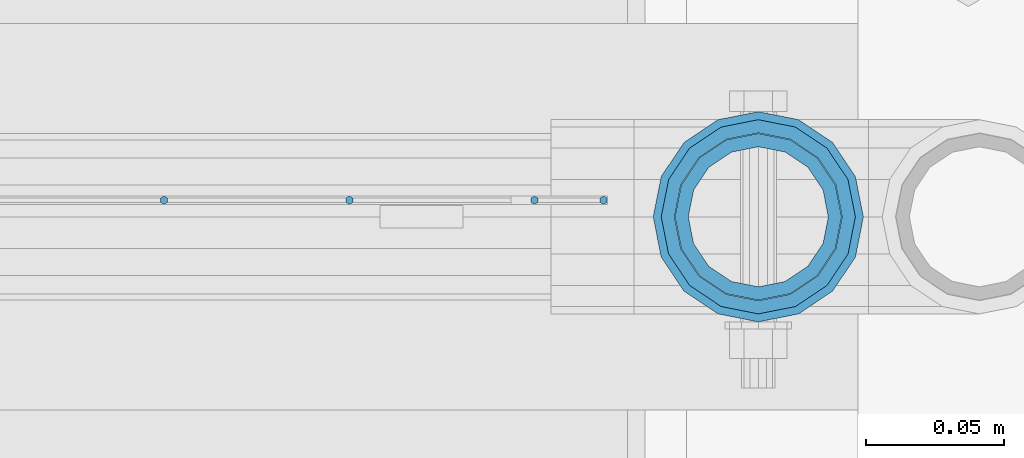
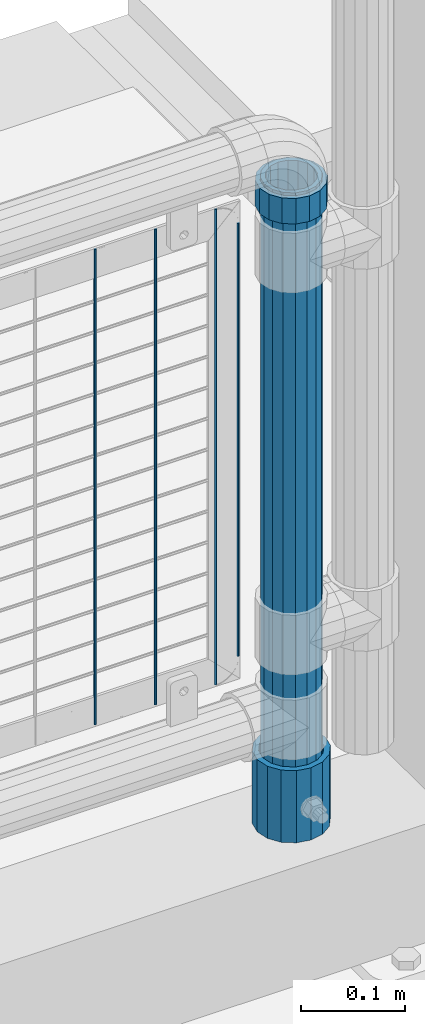
# One storey, part 99 of 257: 7 columns.
"""IFC2X3 building model written with IfcOpenShell, lengths in millimetres."""

from ifc_helpers import new_model, si_unit, frame, origin_with_axes, place, context, subcontext, project, spatial, faceted_brep, material, type_object, element, save


model = new_model("IFC2X3")

# Units and contexts
model_context = context("Model", 3, precision=1e-05, world=origin_with_axes())
body_context = subcontext(model_context, "Body", "Model", "MODEL_VIEW")
ifc_project = project(units=[si_unit("LENGTHUNIT", "METRE", prefix="MILLI"), si_unit("AREAUNIT", "SQUARE_METRE"), si_unit("VOLUMEUNIT", "CUBIC_METRE"), si_unit("MASSUNIT", "GRAM", prefix="KILO"), si_unit("TIMEUNIT", "SECOND"), si_unit("PLANEANGLEUNIT", "RADIAN"), si_unit("SOLIDANGLEUNIT", "STERADIAN"), si_unit("THERMODYNAMICTEMPERATUREUNIT", "DEGREE_CELSIUS"), si_unit("LUMINOUSINTENSITYUNIT", "LUMEN")], contexts=[model_context])

# Site, building, storey
site_placement = place(None, origin_with_axes())
site = spatial("IfcSite", under=ifc_project, at=site_placement, CompositionType="ELEMENT")
building_placement = place(site_placement, origin_with_axes())
building = spatial("IfcBuilding", under=site, at=building_placement, Name="Standard", CompositionType="ELEMENT")
storey_placement = place(building_placement, origin_with_axes())
storey = spatial("IfcBuildingStorey", under=building, at=storey_placement, Name="Undefined", CompositionType="ELEMENT", Elevation=0.0)

# Columns
ifc_material_1 = material()
column_type_1 = type_object("IfcColumnType", PredefinedType="NOTDEFINED")
column_1_placement = place(storey_placement, frame((58671.0, 10664.5, 168.019999999998), z_axis=(0.0, 1.0, 0.0), x_axis=(0.0, 0.0, 1.0)))
element("IfcColumn", 1, at=column_1_placement, inside=storey, type_object=column_type_1, material=ifc_material_1, context=body_context, shape_type="Brep", body=[
    faceted_brep([(0.0, -31.75, 0.0), (0.0, -29.3331751572332, 12.1501989775916), (85.0, -29.3331751572332, 12.1501989775916), (85.0, -31.75, 0.0), (0.0, -22.4506403026753, 22.4506403026735), (85.0, -22.4506403026753, 22.4506403026735), (0.0, -12.1501989775934, 29.3331751572332), (85.0, -12.1501989775934, 29.3331751572332), (0.0, 0.0, 31.75), (85.0, 0.0, 31.75), (0.0, 12.1501989775934, 29.3331751572332), (85.0, 12.1501989775934, 29.3331751572332), (0.0, 22.4506403026753, 22.4506403026735), (85.0, 22.4506403026753, 22.4506403026735), (0.0, 29.3331751572332, 12.1501989775916), (85.0, 29.3331751572332, 12.1501989775916), (0.0, 31.75, 0.0), (85.0, 31.75, 0.0), (0.0, 29.3331751572332, -12.1501989775916), (85.0, 29.3331751572332, -12.1501989775916), (0.0, 22.4506403026753, -22.4506403026735), (85.0, 22.4506403026753, -22.4506403026735), (0.0, 12.1501989775934, -29.3331751572332), (85.0, 12.1501989775934, -29.3331751572332), (0.0, 0.0, -31.75), (85.0, 0.0, -31.75), (0.0, -12.1501989775934, -29.3331751572332), (85.0, -12.1501989775934, -29.3331751572332), (0.0, -22.4506403026753, -22.4506403026735), (85.0, -22.4506403026753, -22.4506403026735), (0.0, -29.3331751572332, -12.1501989775916), (85.0, -29.3331751572332, -12.1501989775916), (0.0, -38.0500000000029, 0.0), (0.0, -35.1536162120537, -14.561104601491), (85.0, -35.1536162120537, -14.561104601491), (85.0, -38.0500000000029, 0.0), (0.0, -26.9054130241493, -26.9054130241475), (85.0, -26.9054130241493, -26.9054130241475), (0.0, -14.5611046014892, -35.1536162120537), (85.0, -14.5611046014892, -35.1536162120537), (0.0, 0.0, -38.0499999999993), (85.0, 0.0, -38.0499999999993), (0.0, 14.5611046014892, -35.1536162120537), (85.0, 14.5611046014892, -35.1536162120537), (0.0, 26.9054130241493, -26.9054130241475), (85.0, 26.9054130241493, -26.9054130241475), (0.0, 35.1536162120537, -14.561104601491), (85.0, 35.1536162120537, -14.561104601491), (0.0, 38.0500000000029, 0.0), (85.0, 38.0500000000029, 0.0), (0.0, 35.1536162120537, 14.561104601491), (85.0, 35.1536162120537, 14.561104601491), (0.0, 26.9054130241493, 26.9054130241475), (85.0, 26.9054130241493, 26.9054130241475), (0.0, 14.5611046014892, 35.1536162120537), (85.0, 14.5611046014892, 35.1536162120537), (0.0, 0.0, 38.0499999999993), (85.0, 0.0, 38.0499999999993), (0.0, -14.5611046014892, 35.1536162120537), (85.0, -14.5611046014892, 35.1536162120537), (0.0, -26.9054130241493, 26.9054130241475), (85.0, -26.9054130241493, 26.9054130241475), (0.0, -35.1536162120537, 14.561104601491), (85.0, -35.1536162120537, 14.561104601491)], [[[0, 1, 2, 3]], [[1, 4, 5, 2]], [[4, 6, 7, 5]], [[6, 8, 9, 7]], [[8, 10, 11, 9]], [[10, 12, 13, 11]], [[12, 14, 15, 13]], [[14, 16, 17, 15]], [[16, 18, 19, 17]], [[18, 20, 21, 19]], [[20, 22, 23, 21]], [[22, 24, 25, 23]], [[24, 26, 27, 25]], [[26, 28, 29, 27]], [[28, 30, 31, 29]], [[30, 0, 3, 31]], [[32, 33, 34, 35]], [[33, 36, 37, 34]], [[36, 38, 39, 37]], [[38, 40, 41, 39]], [[40, 42, 43, 41]], [[42, 44, 45, 43]], [[44, 46, 47, 45]], [[46, 48, 49, 47]], [[48, 50, 51, 49]], [[50, 52, 53, 51]], [[52, 54, 55, 53]], [[54, 56, 57, 55]], [[56, 58, 59, 57]], [[58, 60, 61, 59]], [[60, 62, 63, 61]], [[62, 32, 35, 63]], [[37, 39, 41, 43, 45, 47, 49, 51, 53, 55, 57, 59, 61, 63, 35, 34], [5, 7, 9, 11, 13, 15, 17, 19, 21, 23, 25, 27, 29, 31, 3, 2]], [[62, 60, 58, 56, 54, 52, 50, 48, 46, 44, 42, 40, 38, 36, 33, 32], [30, 28, 26, 24, 22, 20, 18, 16, 14, 12, 10, 8, 6, 4, 1, 0]]]),
])
ifc_material_2 = material(Name="Misc_Undefined")
column_type_2 = type_object("IfcColumnType", PredefinedType="NOTDEFINED")
column_2_placement = place(storey_placement, frame((58671.0, 10664.5, 894.85), z_axis=(1.0, 0.0, 0.0), x_axis=(0.0, 0.0, 1.0)))
element("IfcColumn", 2, at=column_2_placement, inside=storey, type_object=column_type_2, material=ifc_material_2, context=body_context, shape_type="Brep", body=[
    faceted_brep([(0.0, -30.3500000000004, 0.0), (0.0, -28.0397438117179, 11.6144421722784), (30.0, -28.0397438117179, 11.6144421722805), (30.0, -30.3500000000004, 0.0), (0.0, -21.4606908090118, 21.4606908090136), (30.0, -21.4606908090118, 21.4606908090117), (0.0, -11.6144421722802, 28.0397438117143), (30.0, -11.6144421722802, 28.0397438117175), (0.0, 0.0, 30.3499999999985), (30.0, 0.0, 30.35), (0.0, 11.6144421722802, 28.0397438117143), (30.0, 11.6144421722802, 28.0397438117175), (0.0, 21.4606908090118, 21.4606908090136), (30.0, 21.4606908090118, 21.4606908090117), (0.0, 28.0397438117179, 11.6144421722784), (30.0, 28.0397438117179, 11.6144421722805), (0.0, 30.3500000000004, 0.0), (30.0, 30.3500000000004, 0.0), (0.0, 28.0397438117179, -11.6144421722784), (30.0, 28.0397438117179, -11.6144421722805), (0.0, 21.4606908090118, -21.4606908090136), (30.0, 21.4606908090118, -21.4606908090117), (0.0, 11.6144421722802, -28.0397438117143), (30.0, 11.6144421722802, -28.0397438117175), (0.0, 0.0, -30.3499999999985), (30.0, 0.0, -30.35), (0.0, -11.6144421722802, -28.0397438117143), (30.0, -11.6144421722802, -28.0397438117175), (0.0, -21.4606908090118, -21.4606908090136), (30.0, -21.4606908090118, -21.4606908090117), (0.0, -28.0397438117179, -11.6144421722784), (30.0, -28.0397438117179, -11.6144421722805), (0.0, -35.1499999999996, 0.0), (0.0, -32.4743655677721, -13.4513226476338), (30.0, -32.4743655677721, -13.4513226476329), (30.0, -35.1499999999996, 0.0), (0.0, -24.8548033587067, -24.8548033587067), (30.0, -24.8548033587067, -24.8548033587072), (0.0, -13.4513226476338, -32.4743655677739), (30.0, -13.4513226476338, -32.4743655677717), (0.0, 0.0, -35.1499999999996), (30.0, 0.0, -35.15), (0.0, 13.4513226476338, -32.4743655677739), (30.0, 13.4513226476338, -32.4743655677717), (0.0, 24.8548033587067, -24.8548033587067), (30.0, 24.8548033587067, -24.8548033587072), (0.0, 32.4743655677721, -13.4513226476338), (30.0, 32.4743655677721, -13.4513226476329), (0.0, 35.1499999999996, 0.0), (30.0, 35.1499999999996, 0.0), (0.0, 32.4743655677721, 13.4513226476338), (30.0, 32.4743655677721, 13.4513226476329), (0.0, 24.8548033587067, 24.8548033587067), (30.0, 24.8548033587067, 24.8548033587072), (0.0, 13.4513226476338, 32.4743655677739), (30.0, 13.4513226476338, 32.4743655677717), (0.0, 0.0, 35.1499999999996), (30.0, 0.0, 35.15), (0.0, -13.4513226476338, 32.4743655677739), (30.0, -13.4513226476338, 32.4743655677717), (0.0, -24.8548033587067, 24.8548033587067), (30.0, -24.8548033587067, 24.8548033587072), (0.0, -32.4743655677721, 13.4513226476338), (30.0, -32.4743655677721, 13.4513226476329)], [[[0, 1, 2, 3]], [[1, 4, 5, 2]], [[4, 6, 7, 5]], [[6, 8, 9, 7]], [[8, 10, 11, 9]], [[10, 12, 13, 11]], [[12, 14, 15, 13]], [[14, 16, 17, 15]], [[16, 18, 19, 17]], [[18, 20, 21, 19]], [[20, 22, 23, 21]], [[22, 24, 25, 23]], [[24, 26, 27, 25]], [[26, 28, 29, 27]], [[28, 30, 31, 29]], [[30, 0, 3, 31]], [[32, 33, 34, 35]], [[33, 36, 37, 34]], [[36, 38, 39, 37]], [[38, 40, 41, 39]], [[40, 42, 43, 41]], [[42, 44, 45, 43]], [[44, 46, 47, 45]], [[46, 48, 49, 47]], [[48, 50, 51, 49]], [[50, 52, 53, 51]], [[52, 54, 55, 53]], [[54, 56, 57, 55]], [[56, 58, 59, 57]], [[58, 60, 61, 59]], [[60, 62, 63, 61]], [[62, 32, 35, 63]], [[37, 39, 41, 43, 45, 47, 49, 51, 53, 55, 57, 59, 61, 63, 35, 34], [5, 7, 9, 11, 13, 15, 17, 19, 21, 23, 25, 27, 29, 31, 3, 2]], [[62, 60, 58, 56, 54, 52, 50, 48, 46, 44, 42, 40, 38, 36, 33, 32], [30, 28, 26, 24, 22, 20, 18, 16, 14, 12, 10, 8, 6, 4, 1, 0]]]),
])
column_type_3 = type_object("IfcColumnType", PredefinedType="NOTDEFINED")
column_3_placement = place(storey_placement, frame((58671.0, 10664.5, 168.019999999998), z_axis=(-1.0, 0.0, 0.0), x_axis=(0.0, 0.0, 1.0)))
element("IfcColumn", 3, at=column_3_placement, inside=storey, type_object=column_type_3, material=ifc_material_1, context=body_context, shape_type="Brep", body=[
    faceted_brep([(0.0, -25.3500000000004, 0.0), (0.0, -23.4203461491616, 9.70102501045767), (760.0, -23.4203461491616, 9.70102501045767), (760.0, -25.3500000000004, 0.0), (0.0, -17.9251569030785, 17.9251569030821), (760.0, -17.9251569030785, 17.9251569030821), (0.0, -9.70102501045585, 23.4203461491634), (760.0, -9.70102501045585, 23.4203461491634), (0.0, 0.0, 25.3499999999985), (760.0, 0.0, 25.3499999999985), (0.0, 9.70102501045585, 23.4203461491634), (760.0, 9.70102501045585, 23.4203461491634), (0.0, 17.9251569030785, 17.9251569030821), (760.0, 17.9251569030785, 17.9251569030821), (0.0, 23.4203461491616, 9.70102501045767), (760.0, 23.4203461491616, 9.70102501045767), (0.0, 25.3500000000004, 0.0), (760.0, 25.3500000000004, 0.0), (0.0, 23.4203461491616, -9.70102501045767), (760.0, 23.4203461491616, -9.70102501045767), (0.0, 17.9251569030785, -17.9251569030821), (760.0, 17.9251569030785, -17.9251569030821), (0.0, 9.70102501045585, -23.4203461491634), (760.0, 9.70102501045585, -23.4203461491634), (0.0, 0.0, -25.3499999999985), (760.0, 0.0, -25.3499999999985), (0.0, -9.70102501045585, -23.4203461491634), (760.0, -9.70102501045585, -23.4203461491634), (0.0, -17.9251569030785, -17.9251569030821), (760.0, -17.9251569030785, -17.9251569030821), (0.0, -23.4203461491616, -9.70102501045767), (760.0, -23.4203461491616, -9.70102501045767), (0.0, -30.1499999999996, 0.0), (0.0, -27.8549679052157, -11.5379054858058), (760.0, -27.8549679052157, -11.5379054858058), (760.0, -30.1499999999996, 0.0), (0.0, -21.3192694527752, -21.3192694527752), (760.0, -21.3192694527752, -21.3192694527752), (0.0, -11.5379054858076, -27.8549679052157), (760.0, -11.5379054858076, -27.8549679052157), (0.0, 0.0, -30.1500000000015), (760.0, 0.0, -30.1500000000015), (0.0, 11.5379054858076, -27.8549679052157), (760.0, 11.5379054858076, -27.8549679052157), (0.0, 21.3192694527752, -21.3192694527752), (760.0, 21.3192694527752, -21.3192694527752), (0.0, 27.8549679052157, -11.5379054858058), (760.0, 27.8549679052157, -11.5379054858058), (0.0, 30.1499999999996, 0.0), (760.0, 30.1499999999996, 0.0), (0.0, 27.8549679052157, 11.5379054858058), (760.0, 27.8549679052157, 11.5379054858058), (0.0, 21.3192694527752, 21.3192694527752), (760.0, 21.3192694527752, 21.3192694527752), (0.0, 11.5379054858076, 27.8549679052157), (760.0, 11.5379054858076, 27.8549679052157), (0.0, 0.0, 30.1500000000015), (760.0, 0.0, 30.1500000000015), (0.0, -11.5379054858076, 27.8549679052157), (760.0, -11.5379054858076, 27.8549679052157), (0.0, -21.3192694527752, 21.3192694527752), (760.0, -21.3192694527752, 21.3192694527752), (0.0, -27.8549679052157, 11.5379054858058), (760.0, -27.8549679052157, 11.5379054858058)], [[[0, 1, 2, 3]], [[1, 4, 5, 2]], [[4, 6, 7, 5]], [[6, 8, 9, 7]], [[8, 10, 11, 9]], [[10, 12, 13, 11]], [[12, 14, 15, 13]], [[14, 16, 17, 15]], [[16, 18, 19, 17]], [[18, 20, 21, 19]], [[20, 22, 23, 21]], [[22, 24, 25, 23]], [[24, 26, 27, 25]], [[26, 28, 29, 27]], [[28, 30, 31, 29]], [[30, 0, 3, 31]], [[32, 33, 34, 35]], [[33, 36, 37, 34]], [[36, 38, 39, 37]], [[38, 40, 41, 39]], [[40, 42, 43, 41]], [[42, 44, 45, 43]], [[44, 46, 47, 45]], [[46, 48, 49, 47]], [[48, 50, 51, 49]], [[50, 52, 53, 51]], [[52, 54, 55, 53]], [[54, 56, 57, 55]], [[56, 58, 59, 57]], [[58, 60, 61, 59]], [[60, 62, 63, 61]], [[62, 32, 35, 63]], [[37, 39, 41, 43, 45, 47, 49, 51, 53, 55, 57, 59, 61, 63, 35, 34], [5, 7, 9, 11, 13, 15, 17, 19, 21, 23, 25, 27, 29, 31, 3, 2]], [[62, 60, 58, 56, 54, 52, 50, 48, 46, 44, 42, 40, 38, 36, 33, 32], [30, 28, 26, 24, 22, 20, 18, 16, 14, 12, 10, 8, 6, 4, 1, 0]]]),
])
column_type_4 = type_object("IfcColumnType", Name="D3", PredefinedType="NOTDEFINED")
for number, where, z_axis, x_axis in (
    (4, (58590.0020000001, 10670.4997841009, 353.02), (-1.0, 0.0, 0.0), (0.0, 0.0, 1.0)),
    (5, (58522.9740000001, 10670.4997983097, 353.02), (-1.0, 0.0, 0.0), (0.0, 0.0, 1.0)),
    (6, (58455.9460000001, 10670.4998125185, 353.02), (-1.0, 0.0, 0.0), (0.0, 0.0, 1.0)),
):
    element("IfcColumn", number, at=place(storey_placement, frame(where, z_axis=z_axis, x_axis=x_axis)), inside=storey, type_object=column_type_4, material=ifc_material_2, ObjectType="D3", context=body_context, shape_type="Brep", body=[
        faceted_brep([(0.0, -1.5, -5.6843418860808e-14), (0.0, -0.750000000001819, -1.29903810567669), (560.0, -0.75, -1.29903810567339), (560.0, -1.5, 0.0), (7.27595761418343e-12, 0.749999999998181, -1.29903810567669), (560.0, 0.75, -1.29903810567339), (0.0, 1.5, -5.6843418860808e-14), (560.0, 1.5, 0.0), (7.27595761418343e-12, 0.749999999998181, 1.29903810567669), (560.0, 0.75, 1.29903810567339), (0.0, -0.750000000001819, 1.29903810567669), (560.0, -0.75, 1.29903810567339)], [[[0, 1, 2, 3]], [[1, 4, 5, 2]], [[4, 6, 7, 5]], [[6, 8, 9, 7]], [[8, 10, 11, 9]], [[10, 0, 3, 11]], [[5, 7, 9, 11, 3, 2]], [[10, 8, 6, 4, 1, 0]]]),
    ])
column_4_placement = place(storey_placement, frame((58615.0000000001, 10670.4997788013, 378.02), z_axis=(-1.0, 0.0, 0.0), x_axis=(0.0, 0.0, 1.0)))
element("IfcColumn", 7, at=column_4_placement, inside=storey, type_object=column_type_4, material=ifc_material_2, ObjectType="D3", context=body_context, shape_type="Brep", body=[
    faceted_brep([(0.0, -1.5, -5.6843418860808e-14), (0.0, -0.750000000001819, -1.29903810567669), (510.0, -0.75, -1.29903810567339), (510.0, -1.5, 0.0), (7.27595761418343e-12, 0.749999999998181, -1.29903810567669), (510.0, 0.75, -1.29903810567339), (0.0, 1.5, -5.6843418860808e-14), (510.0, 1.5, 0.0), (7.27595761418343e-12, 0.749999999998181, 1.29903810567669), (510.0, 0.75, 1.29903810567339), (0.0, -0.750000000001819, 1.29903810567669), (510.0, -0.75, 1.29903810567339)], [[[0, 1, 2, 3]], [[1, 4, 5, 2]], [[4, 6, 7, 5]], [[6, 8, 9, 7]], [[8, 10, 11, 9]], [[10, 0, 3, 11]], [[5, 7, 9, 11, 3, 2]], [[10, 8, 6, 4, 1, 0]]]),
])

save(model, "model.ifc")
